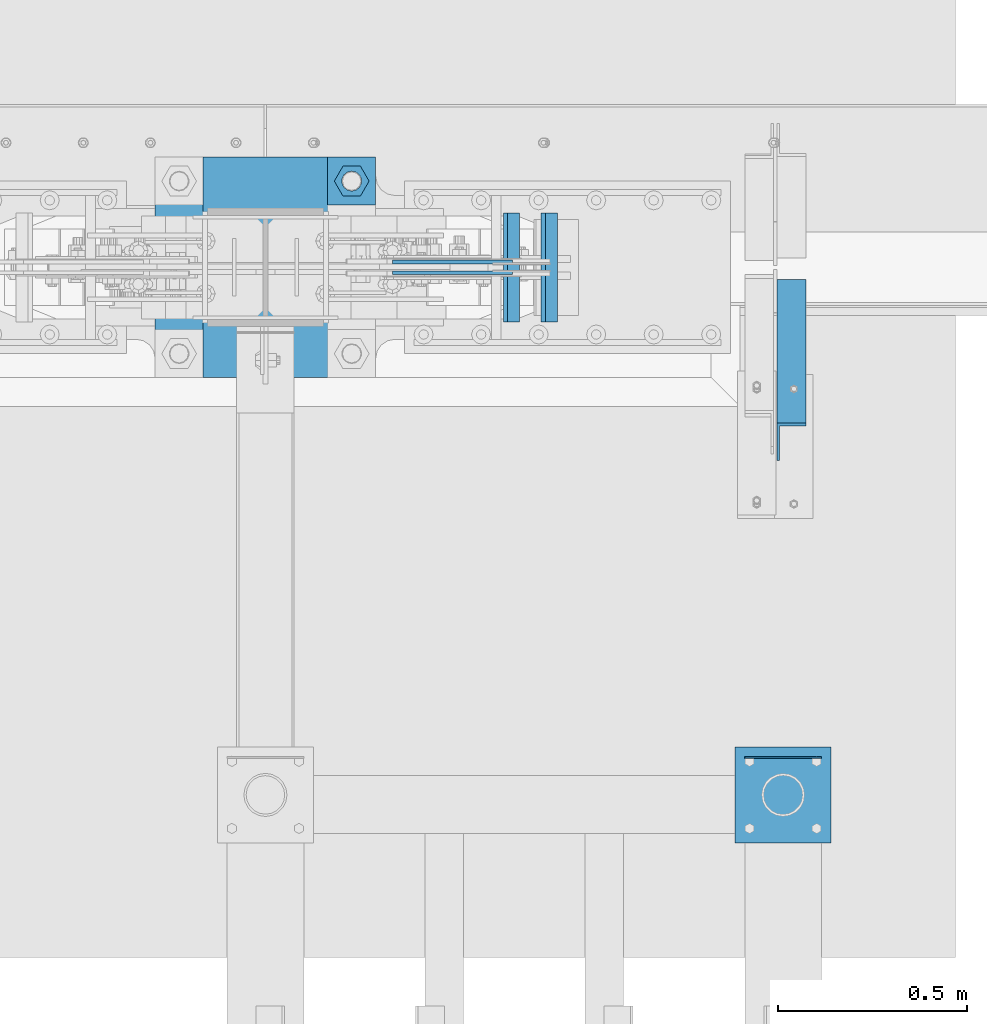
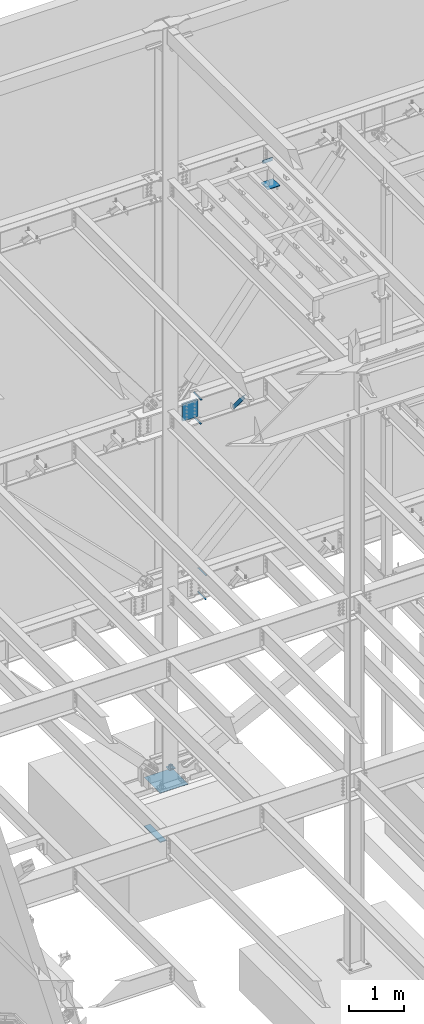
# One storey, part 888 of 1179: 12 beams, 1 member, 7 elements without a shape of their own.
"""IFC2X3 building model written with IfcOpenShell, lengths in millimetres."""

from ifc_helpers import new_model, si_unit, frame, origin_with_axes, place, context, subcontext, project, spatial, faceted_brep, material, type_object, element, aggregate, save


model = new_model("IFC2X3")

# Units and contexts
model_context = context("Model", 3, precision=1e-05, world=origin_with_axes())
body_context = subcontext(model_context, "Body", "Model", "MODEL_VIEW")
ifc_project = project(units=[si_unit("LENGTHUNIT", "METRE", prefix="MILLI"), si_unit("AREAUNIT", "SQUARE_METRE"), si_unit("VOLUMEUNIT", "CUBIC_METRE"), si_unit("MASSUNIT", "GRAM", prefix="KILO"), si_unit("TIMEUNIT", "SECOND"), si_unit("PLANEANGLEUNIT", "RADIAN"), si_unit("SOLIDANGLEUNIT", "STERADIAN"), si_unit("THERMODYNAMICTEMPERATUREUNIT", "DEGREE_CELSIUS"), si_unit("LUMINOUSINTENSITYUNIT", "LUMEN")], contexts=[model_context])

# Site, building, storey
site_placement = place(None, origin_with_axes())
site = spatial("IfcSite", under=ifc_project, at=site_placement, CompositionType="ELEMENT")
building_placement = place(site_placement, origin_with_axes())
building = spatial("IfcBuilding", under=site, at=building_placement, Name="Undefined", CompositionType="ELEMENT")
storey_placement = place(building_placement, origin_with_axes())
storey = spatial("IfcBuildingStorey", under=building, at=storey_placement, Name="Undefined", CompositionType="ELEMENT", Elevation=0.0)

# Assembly, beam
assembly_1_placement = place(storey_placement, origin_with_axes())
assembly_1 = element("IfcElementAssembly", 1, at=assembly_1_placement, inside=storey, Name="TEMPLATE", AssemblyPlace="NOTDEFINED", PredefinedType="RIGID_FRAME")
ifc_material_1 = material(Name="STEEL/A36")
beam_type_1 = type_object("IfcBeamType", PredefinedType="NOTDEFINED")
beam_1_placement = place(assembly_1_placement, frame((8445.5, 41427.3999938965, -207.9625), z_axis=(0.0, 1.0, 0.0), x_axis=(1.0, 0.0, 0.0)))
beam_1 = element("IfcBeam", 2, at=beam_1_placement, type_object=beam_type_1, material=ifc_material_1, Name="SQ WASHER", context=body_context, shape_type="Brep", body=[
    faceted_brep([(0.0, 7.9375, -63.5), (0.0, 7.9375, 63.5), (127.0, 7.9375, 63.5), (127.0, 7.9375, -63.5), (0.0, -7.9375, 63.5), (127.0, -7.9375, 63.5), (0.0, -7.9375, -63.5), (127.0, -7.9375, -63.5)], [[[0, 1, 2, 3]], [[1, 4, 5, 2]], [[4, 6, 7, 5]], [[6, 0, 3, 7]], [[5, 7, 3, 2]], [[6, 4, 1, 0]]]),
])

assembly_2_placement = place(storey_placement, origin_with_axes())
assembly_2 = element("IfcElementAssembly", 3, at=assembly_2_placement, inside=storey, Name="FRAME", AssemblyPlace="NOTDEFINED", PredefinedType="RIGID_FRAME")
beam_type_2 = type_object("IfcBeamType", PredefinedType="NOTDEFINED")
beam_2_placement = place(assembly_2_placement, frame((9550.4, 39900.3534873485, 13722.35), z_axis=(0.0, 0.0, 1.0), x_axis=(1.0, 0.0, 0.0)))
beam_2 = element("IfcBeam", 4, at=beam_2_placement, type_object=beam_type_2, material=ifc_material_1, Name="PLATE", context=body_context, shape_type="Brep", body=[
    faceted_brep([(0.0, 2.38149999999951, -38.0999999999985), (0.0, 2.38149999999951, 38.0999999999985), (203.199999999997, 2.38150000000314, 38.1000000000004), (203.199999999997, 2.38150000000314, -38.1000000000004), (0.0, -2.38149999999951, 38.0999999999985), (203.199999999997, -2.38150000000314, 38.1000000000004), (0.0, -2.38149999999951, -38.0999999999985), (203.199999999997, -2.38150000000314, -38.1000000000004)], [[[0, 1, 2, 3]], [[1, 4, 5, 2]], [[4, 6, 7, 5]], [[6, 0, 3, 7]], [[5, 7, 3, 2]], [[6, 4, 1, 0]]]),
])

# Assembly, member
assembly_3_placement = place(storey_placement, origin_with_axes())
assembly_3 = element("IfcElementAssembly", 5, at=assembly_3_placement, inside=storey, Name="ANGLE", AssemblyPlace="NOTDEFINED", PredefinedType="RIGID_FRAME")
member_type = type_object("IfcMemberType", Name="L3X3X1/4", PredefinedType="NOTDEFINED")
member_placement = place(assembly_3_placement, frame((9674.225, 41137.0679040265, 7518.83524528677), z_axis=(0.0, -0.767806695844832, -0.640681572870519), x_axis=(0.0, -0.640681572870519, 0.767806695844831)))
member = element("IfcMember", 6, at=member_placement, type_object=member_type, material=ifc_material_1, Name="ANGLE", ObjectType="L3X3X1/4", context=body_context, shape_type="Brep", body=[
    faceted_brep([(0.0, 38.0999999999985, -38.0999999999999), (0.0, 38.0999999999985, 38.0999999999999), (655.633410548446, 38.1000000000004, 38.0999999994965), (592.049781860664, 38.1000000000004, -38.1000000005733), (0.0, 31.75, 38.1000000000004), (655.633410548446, 31.75, 38.0999999994965), (0.0, 31.75, -31.75), (597.348417584646, 31.75, -31.7500000005675), (0.0, -38.0999999999985, -31.75), (597.348417584646, -38.1000000000004, -31.7500000005675), (0.0, -38.0999999999985, -38.0999999999999), (592.049781860664, -38.1000000000004, -38.1000000005733)], [[[0, 1, 2, 3]], [[1, 4, 5, 2]], [[4, 6, 7, 5]], [[6, 8, 9, 7]], [[8, 10, 11, 9]], [[10, 0, 3, 11]], [[5, 7, 9, 11, 3, 2]], [[10, 8, 6, 4, 1, 0]]]),
])
aggregate(assembly_3, [member])

# Assembly, beams
assembly_4_placement = place(storey_placement, origin_with_axes())
assembly_4 = element("IfcElementAssembly", 7, at=assembly_4_placement, inside=storey, Name="BEAM", AssemblyPlace="NOTDEFINED", PredefinedType="RIGID_FRAME")
ifc_material_2 = material(Name="STEEL/A572-GR.50")
beam_type_3 = type_object("IfcBeamType", PredefinedType="NOTDEFINED")
beam_3_placement = place(assembly_4_placement, frame((8942.6843184184, 41198.7999633791, 7459.6625), z_axis=(0.0, 1.0, 0.0), x_axis=(-1.0, 0.0, 0.0)))
beam_3 = element("IfcBeam", 8, at=beam_3_placement, type_object=beam_type_3, material=ifc_material_2, Name="PLATE", context=body_context, shape_type="Brep", body=[
    faceted_brep([(0.0, 4.76249999999982, -144.462500000001), (0.0, 4.76249999999982, 144.462500000001), (31.7500000000036, 4.76249999999982, 144.462500000001), (31.7500000000036, 4.76249999999982, -144.462500000001), (0.0, -4.76249999999982, 144.462500000001), (31.7500000000036, -4.76249999999982, 144.462500000001), (0.0, -4.76249999999982, -144.462500000001), (31.7500000000036, -4.76249999999982, -144.462500000001)], [[[0, 1, 2, 3]], [[1, 4, 5, 2]], [[4, 6, 7, 5]], [[6, 0, 3, 7]], [[5, 7, 3, 2]], [[6, 4, 1, 0]]]),
])
beam_4_placement = place(assembly_4_placement, frame((8953.79640199402, 41198.7999633791, 7984.72549025941), z_axis=(0.0, 1.0, 0.0), x_axis=(-1.0, 0.0, 0.0)))
beam_4 = element("IfcBeam", 9, at=beam_4_placement, type_object=beam_type_3, material=ifc_material_2, Name="PLATE", context=body_context, shape_type="Brep", body=[
    faceted_brep([(0.0, 4.76249999999982, -144.462500000001), (0.0, 4.76249999999982, 144.462500000001), (31.7500000000036, 4.76249999999982, 144.462500000001), (31.7500000000036, 4.76249999999982, -144.462500000001), (0.0, -4.76249999999982, 144.462500000001), (31.7500000000036, -4.76249999999982, 144.462500000001), (0.0, -4.76249999999982, -144.462500000001), (31.7500000000036, -4.76249999999982, -144.462500000001)], [[[0, 1, 2, 3]], [[1, 4, 5, 2]], [[4, 6, 7, 5]], [[6, 0, 3, 7]], [[5, 7, 3, 2]], [[6, 4, 1, 0]]]),
])
aggregate(assembly_4, [beam_3, beam_4])

assembly_5_placement = place(storey_placement, origin_with_axes())
assembly_5 = element("IfcElementAssembly", 10, at=assembly_5_placement, inside=storey, Name="BEAM", AssemblyPlace="NOTDEFINED", PredefinedType="RIGID_FRAME")
beam_5_placement = place(assembly_5_placement, frame((9042.92744265887, 41198.8000366209, 3548.0625), z_axis=(0.0, -1.0, 0.0), x_axis=(-1.0, 0.0, 0.0)))
beam_5 = element("IfcBeam", 11, at=beam_5_placement, type_object=beam_type_3, material=ifc_material_2, Name="PLATE", context=body_context, shape_type="Brep", body=[
    faceted_brep([(0.0, 4.76249999999982, -144.462500000001), (0.0, 4.76249999999982, 144.462500000001), (31.7500000000036, 4.76249999999982, 144.462500000001), (31.7500000000036, 4.76249999999982, -144.462500000001), (0.0, -4.76249999999982, 144.462500000001), (31.7500000000036, -4.76249999999982, 144.462500000001), (0.0, -4.76249999999982, -144.462500000001), (31.7500000000036, -4.76249999999982, -144.462500000001)], [[[0, 1, 2, 3]], [[1, 4, 5, 2]], [[4, 6, 7, 5]], [[6, 0, 3, 7]], [[5, 7, 3, 2]], [[6, 4, 1, 0]]]),
])
beam_6_placement = place(assembly_5_placement, frame((9054.03952609227, 41198.8000366209, 4073.128), z_axis=(0.0, -1.0, 0.0), x_axis=(-1.0, 0.0, 0.0)))
beam_6 = element("IfcBeam", 12, at=beam_6_placement, type_object=beam_type_3, material=ifc_material_2, Name="PLATE", context=body_context, shape_type="Brep", body=[
    faceted_brep([(0.0, 4.76249999999982, -144.462500000001), (0.0, 4.76249999999982, 144.462500000001), (31.7500000000036, 4.76249999999982, 144.462500000001), (31.7500000000036, 4.76249999999982, -144.462500000001), (0.0, -4.76249999999982, 144.462500000001), (31.7500000000036, -4.76249999999982, 144.462500000001), (0.0, -4.76249999999982, -144.462500000001), (31.7500000000036, -4.76249999999982, -144.462500000001)], [[[0, 1, 2, 3]], [[1, 4, 5, 2]], [[4, 6, 7, 5]], [[6, 0, 3, 7]], [[5, 7, 3, 2]], [[6, 4, 1, 0]]]),
])
aggregate(assembly_5, [beam_5, beam_6])

# Beam
beam_type_4 = type_object("IfcBeamType", PredefinedType="NOTDEFINED")
beam_7_placement = place(assembly_1_placement, frame((8051.7999938965, 41490.9000061035, -1362.075), z_axis=(1.0, 0.0, 0.0), x_axis=(0.0, -1.0, 0.0)))
beam_7 = element("IfcBeam", 13, at=beam_7_placement, type_object=beam_type_4, material=ifc_material_1, Name="SQ WASHER", context=body_context, shape_type="Brep", body=[
    faceted_brep([(0.0, 9.52500000000146, -63.5), (0.0, 9.52500000000146, 63.5), (584.199999999997, 9.52500000000009, 63.5), (584.199999999997, 9.52500000000009, -63.5), (0.0, -9.52500000000146, 63.5), (584.199999999997, -9.52500000000009, 63.5), (0.0, -9.52500000000146, -63.5), (584.199999999997, -9.52500000000009, -63.5)], [[[0, 1, 2, 3]], [[1, 4, 5, 2]], [[4, 6, 7, 5]], [[6, 0, 3, 7]], [[5, 7, 3, 2]], [[6, 4, 1, 0]]]),
])

# Assembly, beam
assembly_6_placement = place(storey_placement, origin_with_axes())
assembly_6 = element("IfcElementAssembly", 14, at=assembly_6_placement, inside=storey, Name="PLATE", AssemblyPlace="NOTDEFINED", PredefinedType="RIGID_FRAME")
beam_type_5 = type_object("IfcBeamType", PredefinedType="NOTDEFINED")
beam_8_placement = place(assembly_6_placement, frame((8617.24646981197, 41184.5125, 7739.05987843069), z_axis=(0.0, 0.0, -1.0), x_axis=(1.0, 0.0, 0.0)))
beam_8 = element("IfcBeam", 15, at=beam_8_placement, type_object=beam_type_5, material=ifc_material_2, Name="PLATE", context=body_context, shape_type="Brep", body=[
    faceted_brep([(0.0, 4.76249999999709, -190.5), (0.0, 4.76249999999709, 190.5), (317.499999999995, 4.76250000000073, 190.500000000051), (317.500000000042, 4.76250000000073, -190.499999999973), (0.0, -4.76249999999709, 190.5), (317.499999999995, -4.76250000000073, 190.500000000051), (0.0, -4.76249999999709, -190.5), (317.500000000042, -4.76250000000073, -190.499999999973)], [[[0, 1, 2, 3]], [[1, 4, 5, 2]], [[4, 6, 7, 5]], [[6, 0, 3, 7]], [[5, 7, 3, 2]], [[6, 4, 1, 0]]]),
])
aggregate(assembly_6, [beam_8])

assembly_7_placement = place(storey_placement, origin_with_axes())
assembly_7 = element("IfcElementAssembly", 16, at=assembly_7_placement, inside=storey, Name="PLATE", AssemblyPlace="NOTDEFINED", PredefinedType="RIGID_FRAME")
beam_9_placement = place(assembly_7_placement, frame((8934.74635853234, 41213.0875, 7739.06186150222), z_axis=(0.0, 0.0, -1.0), x_axis=(-1.0, 0.0, 0.0)))
beam_9 = element("IfcBeam", 17, at=beam_9_placement, type_object=beam_type_5, material=ifc_material_2, Name="PLATE", context=body_context, shape_type="Brep", body=[
    faceted_brep([(0.0, 4.76249999999709, -190.5), (0.0, 4.76249999999709, 190.5), (317.499999999995, 4.76250000000073, 190.500000000051), (317.500000000042, 4.76250000000073, -190.499999999973), (0.0, -4.76249999999709, 190.5), (317.499999999995, -4.76250000000073, 190.500000000051), (0.0, -4.76249999999709, -190.5), (317.500000000042, -4.76250000000073, -190.499999999973)], [[[0, 1, 2, 3]], [[1, 4, 5, 2]], [[4, 6, 7, 5]], [[6, 0, 3, 7]], [[5, 7, 3, 2]], [[6, 4, 1, 0]]]),
])
aggregate(assembly_7, [beam_9])

# Beam
beam_type_6 = type_object("IfcBeamType", PredefinedType="NOTDEFINED")
beam_10_placement = place(assembly_2_placement, frame((9652.0, 39674.1344873485, 13258.8), z_axis=(1.0, 0.0, 0.0), x_axis=(0.0, 1.0, 0.0)))
beam_10 = element("IfcBeam", 18, at=beam_10_placement, type_object=beam_type_6, material=ifc_material_1, Name="PLATE", context=body_context, shape_type="Brep", body=[
    faceted_brep([(0.0, 6.35000000000036, -127.0), (0.0, 6.34999999999854, 127.0), (254.0, 6.35000000000036, 127.0), (254.0, 6.35000000000036, -127.0), (0.0, -6.34999999999854, 127.0), (254.0, -6.35000000000036, 127.0), (0.0, -6.35000000000036, -127.0), (254.0, -6.35000000000036, -127.0)], [[[0, 1, 2, 3]], [[1, 4, 5, 2]], [[4, 6, 7, 5]], [[6, 0, 3, 7]], [[5, 7, 3, 2]], [[6, 4, 1, 0]]]),
])

aggregate(assembly_2, [beam_2, beam_10])

beam_type_7 = type_object("IfcBeamType", PredefinedType="NOTDEFINED")
beam_11_placement = place(assembly_1_placement, frame((7988.3, 41198.8, -277.8125), z_axis=(0.0, 1.0, 0.0), x_axis=(1.0, 0.0, 0.0)))
beam_11 = element("IfcBeam", 19, at=beam_11_placement, type_object=beam_type_7, material=ifc_material_1, Name="TEMPLATE", context=body_context, shape_type="Brep", body=[
    faceted_brep([(0.0, 1.58749999999998, -292.099999999999), (0.0, 1.58749999999998, 292.099999999999), (584.199496459973, 1.58749999999998, 292.099999999999), (584.199496459973, 1.58749999999998, -292.099999999999), (0.0, -1.58749999999998, 292.099999999999), (584.199496459973, -1.58749999999998, 292.099999999999), (0.0, -1.58749999999998, -292.099999999999), (584.199496459973, -1.58749999999998, -292.099999999999)], [[[0, 1, 2, 3]], [[1, 4, 5, 2]], [[4, 6, 7, 5]], [[6, 0, 3, 7]], [[5, 7, 3, 2]], [[6, 4, 1, 0]]]),
])

beam_type_8 = type_object("IfcBeamType", Name="2_HEAVY_HEX_NUT", PredefinedType="NOTDEFINED")
beam_12_placement = place(assembly_1_placement, frame((8509.00000000001, 41427.4, -149.225), z_axis=(0.0, 1.0, 0.0), x_axis=(0.0, 0.0, -1.0)))
beam_12 = element("IfcBeam", 20, at=beam_12_placement, type_object=beam_type_8, material=ifc_material_1, Name="NUT", ObjectType="2_HEAVY_HEX_NUT", context=body_context, shape_type="Brep", body=[
    faceted_brep([(0.0, -46.0369987487793, 9.09494701772928e-13), (0.0, -23.0184993743896, -39.869213104248), (50.7999999999993, -23.0184993743896, -39.869213104248), (50.7999999999993, -46.0369987487793, 9.09494701772928e-13), (0.0, 23.0184993743896, -39.869213104248), (50.7999999999993, 23.0184993743896, -39.869213104248), (0.0, 46.0369987487793, -9.09494701772928e-13), (50.7999999999993, 46.0369987487793, -9.09494701772928e-13), (0.0, 23.0184993743896, 39.869213104248), (50.7999999999993, 23.0184993743896, 39.869213104248), (0.0, -23.0184993743896, 39.869213104248), (50.7999999999993, -23.0184993743896, 39.869213104248), (0.0, 0.0, 26.1940002441406), (0.0, 11.3650617044477, 23.5999013092769), (50.7999999999993, 11.3650617044477, 23.5999013092769), (50.7999999999993, 0.0, 26.1940002441406), (0.0, 20.4791109456419, 16.3316083006703), (50.7999999999993, 20.4791109456419, 16.3316083006703), (0.0, 25.5370200498364, 5.82867859874477), (50.7999999999993, 25.5370200498364, 5.82867859874477), (0.0, 25.5370200498364, -5.82867859874477), (50.7999999999993, 25.5370200498364, -5.82867859874477), (0.0, 20.4791109456419, -16.3316083006703), (50.7999999999993, 20.4791109456419, -16.3316083006703), (0.0, 11.365061704455, -23.5999013092769), (50.7999999999993, 11.365061704455, -23.5999013092769), (0.0, 0.0, -26.1940002441406), (50.7999999999993, 0.0, -26.1940002441406), (0.0, -11.3650617044477, -23.5999013092769), (50.7999999999993, -11.3650617044477, -23.5999013092769), (0.0, -20.4791109456419, -16.3316083006703), (50.7999999999993, -20.4791109456419, -16.3316083006703), (0.0, -25.5370200498364, -5.82867859874477), (50.7999999999993, -25.5370200498364, -5.82867859874477), (0.0, -25.5370200498364, 5.82867859874477), (50.7999999999993, -25.5370200498364, 5.82867859874477), (0.0, -20.4791109456419, 16.3316083006703), (50.7999999999993, -20.4791109456419, 16.3316083006703), (0.0, -11.365061704455, 23.5999013092769), (50.7999999999993, -11.365061704455, 23.5999013092769)], [[[0, 1, 2, 3]], [[1, 4, 5, 2]], [[4, 6, 7, 5]], [[6, 8, 9, 7]], [[8, 10, 11, 9]], [[10, 0, 3, 11]], [[12, 13, 14, 15]], [[13, 16, 17, 14]], [[16, 18, 19, 17]], [[18, 20, 21, 19]], [[20, 22, 23, 21]], [[22, 24, 25, 23]], [[24, 26, 27, 25]], [[26, 28, 29, 27]], [[28, 30, 31, 29]], [[30, 32, 33, 31]], [[32, 34, 35, 33]], [[34, 36, 37, 35]], [[36, 38, 39, 37]], [[38, 12, 15, 39]], [[5, 7, 9, 11, 3, 2], [17, 19, 21, 23, 25, 27, 29, 31, 33, 35, 37, 39, 15, 14]], [[10, 8, 6, 4, 1, 0], [38, 36, 34, 32, 30, 28, 26, 24, 22, 20, 18, 16, 13, 12]]]),
])

aggregate(assembly_1, [beam_12, beam_7, beam_1, beam_11])

save(model, "model.ifc")
